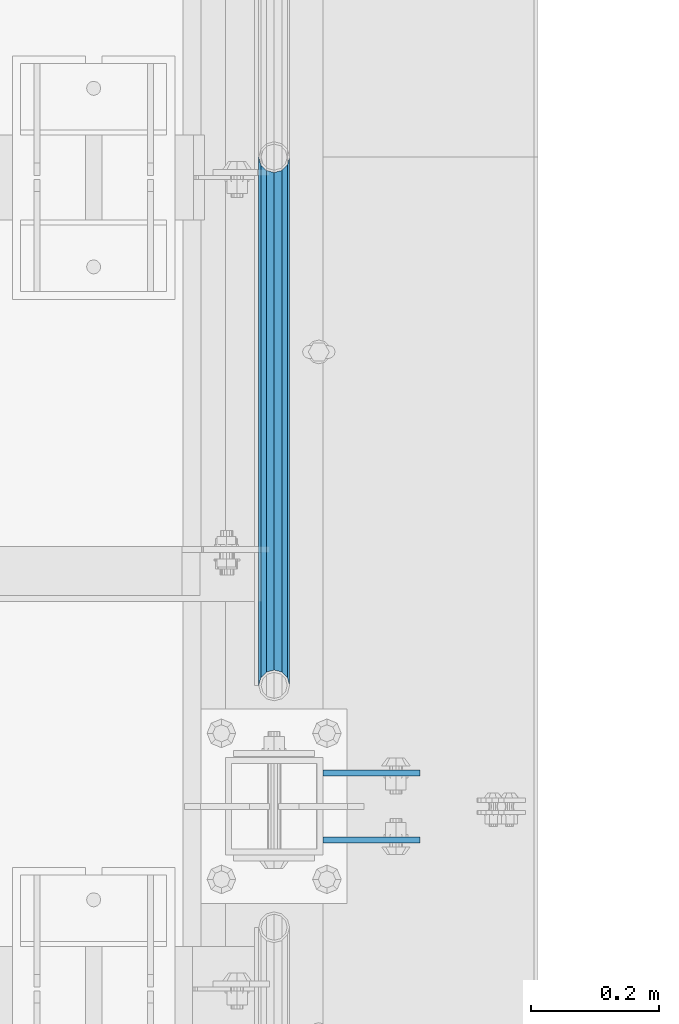
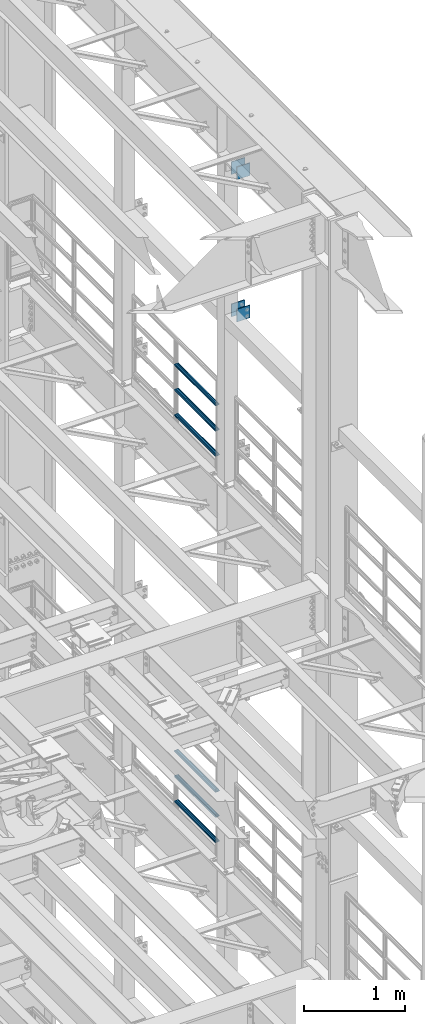
# One storey, part 1345 of 1876: 10 beams, 3 elements without a shape of their own.
"""IFC2X3 building model written with IfcOpenShell, lengths in millimetres."""

from ifc_helpers import new_model, si_unit, frame, origin_with_axes, place, context, subcontext, project, spatial, faceted_brep, material, type_object, element, aggregate, save


model = new_model("IFC2X3")

# Units and contexts
model_context = context("Model", 3, precision=1e-05, world=origin_with_axes())
body_context = subcontext(model_context, "Body", "Model", "MODEL_VIEW")
ifc_project = project(units=[si_unit("LENGTHUNIT", "METRE", prefix="MILLI"), si_unit("AREAUNIT", "SQUARE_METRE"), si_unit("VOLUMEUNIT", "CUBIC_METRE"), si_unit("MASSUNIT", "GRAM", prefix="KILO"), si_unit("TIMEUNIT", "SECOND"), si_unit("PLANEANGLEUNIT", "RADIAN"), si_unit("SOLIDANGLEUNIT", "STERADIAN"), si_unit("THERMODYNAMICTEMPERATUREUNIT", "DEGREE_CELSIUS"), si_unit("LUMINOUSINTENSITYUNIT", "LUMEN")], contexts=[model_context])

# Site, building, storey
site_placement = place(None, origin_with_axes())
site = spatial("IfcSite", under=ifc_project, at=site_placement, CompositionType="ELEMENT")
building_placement = place(site_placement, origin_with_axes())
building = spatial("IfcBuilding", under=site, at=building_placement, Name="Undefined", CompositionType="ELEMENT")
storey_placement = place(building_placement, origin_with_axes())
storey = spatial("IfcBuildingStorey", under=building, at=storey_placement, Name="Undefined", CompositionType="ELEMENT", Elevation=0.0)

# Assembly, beams
assembly_1_placement = place(storey_placement, origin_with_axes())
assembly_1 = element("IfcElementAssembly", 1, at=assembly_1_placement, inside=storey, Name="BEAM", AssemblyPlace="NOTDEFINED", PredefinedType="RIGID_FRAME")
ifc_material_1 = material(Name="STEEL/A36")
beam_type_1 = type_object("IfcBeamType", PredefinedType="NOTDEFINED")
beam_1_placement = place(assembly_1_placement, frame((7696.20000025489, 9704.3875, 21678.9), z_axis=(0.0, 0.0, -1.0), x_axis=(1.0, 0.0, 0.0)))
beam_1 = element("IfcBeam", 2, at=beam_1_placement, type_object=beam_type_1, material=ifc_material_1, Name="PLATE", context=body_context, shape_type="Brep", body=[
    faceted_brep([(0.0, 4.76249999999982, -76.1999999999998), (3.63797880709171e-12, 4.76249999999982, 76.1999969482422), (152.399993896484, 4.76250000000073, 76.1999969482422), (152.4, 4.76249999999982, -76.1999999999998), (3.63797880709171e-12, -4.76249999999982, 76.1999969482422), (152.399993896484, -4.76250000000073, 76.1999969482422), (0.0, -4.76249999999982, -76.1999999999998), (152.4, -4.76249999999982, -76.1999999999998)], [[[0, 1, 2, 3]], [[4, 5, 2, 1]], [[4, 6, 7, 5]], [[6, 0, 3, 7]], [[5, 7, 3, 2]], [[6, 4, 1, 0]]]),
])
beam_2_placement = place(assembly_1_placement, frame((7696.20000025489, 9599.6125, 21678.9), z_axis=(0.0, 0.0, -1.0), x_axis=(1.0, 0.0, 0.0)))
beam_2 = element("IfcBeam", 3, at=beam_2_placement, type_object=beam_type_1, material=ifc_material_1, Name="PLATE", context=body_context, shape_type="Brep", body=[
    faceted_brep([(0.0, 4.76249999999982, -76.1999999999998), (3.63797880709171e-12, 4.76249999999982, 76.1999969482422), (152.399993896484, 4.76250000000073, 76.1999969482422), (152.4, 4.76249999999982, -76.1999999999998), (3.63797880709171e-12, -4.76249999999982, 76.1999969482422), (152.399993896484, -4.76250000000073, 76.1999969482422), (0.0, -4.76249999999982, -76.1999999999998), (152.4, -4.76249999999982, -76.1999999999998)], [[[0, 1, 2, 3]], [[4, 5, 2, 1]], [[4, 6, 7, 5]], [[6, 0, 3, 7]], [[5, 7, 3, 2]], [[6, 4, 1, 0]]]),
])
beam_3_placement = place(assembly_1_placement, frame((7696.20000025489, 9704.3875, 19958.05), z_axis=(0.0, 0.0, -1.0), x_axis=(1.0, 0.0, 0.0)))
beam_3 = element("IfcBeam", 4, at=beam_3_placement, type_object=beam_type_1, material=ifc_material_1, Name="PLATE", context=body_context, shape_type="Brep", body=[
    faceted_brep([(0.0, 4.76249999999982, -76.1999999999998), (3.63797880709171e-12, 4.76249999999982, 76.1999969482422), (152.399993896484, 4.76250000000073, 76.1999969482422), (152.4, 4.76249999999982, -76.1999999999998), (3.63797880709171e-12, -4.76249999999982, 76.1999969482422), (152.399993896484, -4.76250000000073, 76.1999969482422), (0.0, -4.76249999999982, -76.1999999999998), (152.4, -4.76249999999982, -76.1999999999998)], [[[0, 1, 2, 3]], [[4, 5, 2, 1]], [[4, 6, 7, 5]], [[6, 0, 3, 7]], [[5, 7, 3, 2]], [[6, 4, 1, 0]]]),
])
beam_4_placement = place(assembly_1_placement, frame((7696.20000025489, 9599.6125, 19958.05), z_axis=(0.0, 0.0, -1.0), x_axis=(1.0, 0.0, 0.0)))
beam_4 = element("IfcBeam", 5, at=beam_4_placement, type_object=beam_type_1, material=ifc_material_1, Name="PLATE", context=body_context, shape_type="Brep", body=[
    faceted_brep([(0.0, 4.76249999999982, -76.1999999999998), (3.63797880709171e-12, 4.76249999999982, 76.1999969482422), (152.399993896484, 4.76250000000073, 76.1999969482422), (152.4, 4.76249999999982, -76.1999999999998), (3.63797880709171e-12, -4.76249999999982, 76.1999969482422), (152.399993896484, -4.76250000000073, 76.1999969482422), (0.0, -4.76249999999982, -76.1999999999998), (152.4, -4.76249999999982, -76.1999999999998)], [[[0, 1, 2, 3]], [[4, 5, 2, 1]], [[4, 6, 7, 5]], [[6, 0, 3, 7]], [[5, 7, 3, 2]], [[6, 4, 1, 0]]]),
])
aggregate(assembly_1, [beam_1, beam_2, beam_3, beam_4])

assembly_2_placement = place(storey_placement, origin_with_axes())
assembly_2 = element("IfcElementAssembly", 6, at=assembly_2_placement, inside=storey, Name="RAIL", AssemblyPlace="NOTDEFINED", PredefinedType="RIGID_FRAME")
ifc_material_2 = material()
beam_type_2 = type_object("IfcBeamType", Name="PIPE1-1/2SCH40", PredefinedType="NOTDEFINED")
beam_5_placement = place(assembly_2_placement, frame((7620.0, 10668.0, 18145.125), z_axis=(0.0, 0.0, 1.0), x_axis=(0.0, -1.0, 0.0)))
beam_5 = element("IfcBeam", 7, at=beam_5_placement, type_object=beam_type_2, material=ifc_material_2, Name="RAIL", ObjectType="PIPE1-1/2SCH40", context=body_context, shape_type="Brep", body=[
    faceted_brep([(805.872807006681, -12.0649999999996, 20.8971929933177), (805.872807006683, -12.0649999999996, 15.8661214311796), (805.379378568819, -10.2235000000001, 17.7076214311819), (802.640000000001, 0.0, 20.4470000000001), (802.640000000001, 0.0, 24.130000000001), (805.379378568819, 10.2235000000001, 17.7076214311819), (805.872807006683, 12.0649999999996, 15.8661214311796), (805.872807006681, 12.0649999999996, 20.8971929933177), (826.77, 24.1300000000001, 0.0), (814.705, 20.8971929933186, 12.0649999999987), (814.705, 20.8971929933186, -12.0649999999987), (811.515428437862, 17.7076214311801, 10.2235000000001), (814.254807006682, 20.4470000000001, 0.0), (811.515428437862, 17.7076214311801, -10.2235000000001), (805.872807006683, 12.0649999999996, -15.8661214311796), (805.872807006681, 12.0649999999996, -20.8971929933177), (805.379378568819, 10.2235000000001, -17.7076214311819), (802.640000000001, 0.0, -20.4470000000001), (802.640000000001, 0.0, -24.130000000001), (805.872807006683, -12.0649999999996, -15.8661214311796), (805.872807006681, -12.0649999999996, -20.8971929933177), (805.379378568819, -10.2235000000001, -17.7076214311819), (826.77, -24.1300000000001, 0.0), (814.705, -20.8971929933186, -12.0649999999987), (814.705, -20.8971929933186, 12.0649999999987), (811.515428437862, -17.7076214311801, -10.2235000000001), (814.254807006682, -20.4470000000001, 0.0), (811.515428437862, -17.7076214311801, 10.2235000000001), (12.0650000000064, -20.8971929933177, -12.0649999999987), (20.8971929933249, -12.0650000000005, -20.8971929933177), (0.0, 24.1299999999992, 0.0), (12.0650000000064, 20.8971929933177, -12.0649999999987), (12.0650000000064, 20.8971929933177, 12.0649999999987), (20.8971929933249, 12.0650000000005, 20.8971929933177), (24.1300000000064, 0.0, 24.130000000001), (20.8971929933249, 12.0650000000005, -20.8971929933177), (24.1300000000063, 0.0, -24.130000000001), (24.1300000000063, 0.0, -20.4470000000001), (20.8971929933249, -12.0650000000005, -15.8661214311796), (21.3906214311868, -10.2235000000001, -17.7076214311819), (21.3906214311868, 10.2235000000001, -17.7076214311819), (20.8971929933249, 12.0650000000005, -15.8661214311796), (15.2545715621445, 17.7076214311801, -10.2235000000001), (12.5151929933249, 20.4470000000001, 0.0), (15.2545715621445, 17.7076214311801, 10.2235000000001), (20.8971929933249, 12.0650000000005, 15.8661214311796), (21.3906214311868, 10.2235000000001, 17.7076214311819), (24.1300000000064, 0.0, 20.4470000000001), (21.3906214311868, -10.2235000000001, 17.7076214311819), (20.8971929933249, -12.0650000000005, 15.8661214311796), (20.8971929933249, -12.0650000000005, 20.8971929933177), (12.0650000000064, -20.8971929933177, 12.0649999999987), (0.0, -24.1299999999992, 0.0), (15.2545715621445, -17.7076214311801, 10.2235000000001), (12.5151929933249, -20.4470000000001, 0.0), (15.2545715621445, -17.7076214311801, -10.2235000000001)], [[[0, 1, 2, 3, 4]], [[4, 3, 5, 6, 7]], [[8, 9, 10]], [[7, 6, 11, 12, 13, 14, 15, 10, 9]], [[16, 17, 18, 15, 14]], [[19, 20, 18, 17, 21]], [[22, 23, 24]], [[24, 23, 20, 19, 25, 26, 27, 1, 0]], [[28, 29, 20, 23]], [[30, 31, 32]], [[33, 34, 4, 7]], [[32, 33, 7, 9]], [[30, 32, 9, 8]], [[31, 30, 8, 10]], [[35, 31, 10, 15]], [[36, 35, 15, 18]], [[29, 36, 18, 20]], [[37, 36, 29, 38, 39]], [[40, 41, 35, 36, 37]], [[32, 31, 35, 41, 42, 43, 44, 45, 33]], [[33, 45, 46, 47, 34]], [[34, 47, 48, 49, 50]], [[34, 50, 0, 4]], [[50, 51, 24, 0]], [[51, 52, 22, 24]], [[52, 28, 23, 22]], [[51, 28, 52]], [[50, 49, 53, 54, 55, 38, 29, 28, 51]], [[55, 54, 26, 25]], [[21, 39, 38, 55, 25, 19]], [[37, 39, 21, 17]], [[40, 37, 17, 16]], [[42, 41, 40, 16, 14, 13]], [[43, 42, 13, 12]], [[44, 43, 12, 11]], [[5, 46, 45, 44, 11, 6]], [[47, 46, 5, 3]], [[48, 47, 3, 2]], [[53, 49, 48, 2, 1, 27]], [[54, 53, 27, 26]]]),
])
beam_6_placement = place(assembly_2_placement, frame((7620.0, 9841.23, 18449.925), z_axis=(0.0, 0.0, -1.0), x_axis=(0.0, 1.0, 0.0)))
beam_6 = element("IfcBeam", 8, at=beam_6_placement, type_object=beam_type_2, material=ifc_material_2, Name="RAIL", ObjectType="PIPE1-1/2SCH40", context=body_context, shape_type="Brep", body=[
    faceted_brep([(0.0, 24.1299999999992, 0.0), (12.0650000000064, 20.8971929933177, -12.0649999999987), (12.0650000000064, 20.8971929933177, 12.0649999999987), (12.0650000000064, -20.8971929933177, 12.0649999999987), (12.0650000000064, -20.8971929933177, -12.0649999999987), (0.0, -24.1299999999992, 0.0), (20.8971929933249, -12.0650000000005, 20.8971929933177), (20.8971929933249, -12.0650000000005, 15.8661214311796), (15.2545715621445, -17.7076214311801, 10.2235000000001), (12.5151929933249, -20.4470000000001, 0.0), (15.2545715621445, -17.7076214311801, -10.2235000000001), (20.8971929933249, -12.0650000000005, -15.8661214311796), (20.8971929933249, -12.0650000000005, -20.8971929933177), (24.1300000000063, 0.0, -20.4470000000001), (24.1300000000063, 0.0, -24.130000000001), (21.3906214311868, -10.2235000000001, -17.7076214311819), (21.3906214311868, 10.2235000000001, -17.7076214311819), (20.8971929933249, 12.0650000000005, -15.8661214311796), (20.8971929933249, 12.0650000000005, -20.8971929933177), (15.2545715621445, 17.7076214311801, -10.2235000000001), (12.5151929933249, 20.4470000000001, 0.0), (15.2545715621445, 17.7076214311801, 10.2235000000001), (20.8971929933249, 12.0650000000005, 15.8661214311796), (20.8971929933249, 12.0650000000005, 20.8971929933177), (21.3906214311868, 10.2235000000001, 17.7076214311819), (24.1300000000064, 0.0, 20.4470000000001), (24.1300000000064, 0.0, 24.130000000001), (21.3906214311868, -10.2235000000001, 17.7076214311819), (826.77, 24.1300000000001, 0.0), (814.705, 20.8971929933186, -12.0649999999987), (805.872807006681, 12.0649999999996, -20.8971929933177), (826.77, -24.1300000000001, 0.0), (814.705, -20.8971929933186, -12.0649999999987), (814.705, -20.8971929933186, 12.0649999999987), (805.872807006681, -12.0649999999996, 20.8971929933177), (805.872807006681, -12.0649999999996, -20.8971929933177), (802.640000000001, 0.0, -24.130000000001), (805.379378568819, 10.2235000000001, -17.7076214311819), (802.640000000001, 0.0, -20.4470000000001), (805.872807006683, 12.0649999999996, -15.8661214311796), (805.872807006683, -12.0649999999996, -15.8661214311796), (805.379378568819, -10.2235000000001, -17.7076214311819), (811.515428437862, -17.7076214311801, -10.2235000000001), (814.254807006682, -20.4470000000001, 0.0), (811.515428437862, -17.7076214311801, 10.2235000000001), (805.872807006683, -12.0649999999996, 15.8661214311796), (805.379378568819, -10.2235000000001, 17.7076214311819), (802.640000000001, 0.0, 20.4470000000001), (802.640000000001, 0.0, 24.130000000001), (805.872807006681, 12.0649999999996, 20.8971929933177), (814.705, 20.8971929933186, 12.0649999999987), (805.872807006683, 12.0649999999996, 15.8661214311796), (811.515428437862, 17.7076214311801, 10.2235000000001), (814.254807006682, 20.4470000000001, 0.0), (811.515428437862, 17.7076214311801, -10.2235000000001), (805.379378568819, 10.2235000000001, 17.7076214311819)], [[[0, 1, 2]], [[3, 4, 5]], [[6, 7, 8, 9, 10, 11, 12, 4, 3]], [[13, 14, 12, 11, 15]], [[16, 17, 18, 14, 13]], [[2, 1, 18, 17, 19, 20, 21, 22, 23]], [[23, 22, 24, 25, 26]], [[26, 25, 27, 7, 6]], [[1, 0, 28, 29]], [[18, 1, 29, 30]], [[31, 32, 33]], [[6, 3, 33, 34]], [[3, 5, 31, 33]], [[5, 4, 32, 31]], [[4, 12, 35, 32]], [[12, 14, 36, 35]], [[14, 18, 30, 36]], [[37, 38, 36, 30, 39]], [[40, 35, 36, 38, 41]], [[33, 32, 35, 40, 42, 43, 44, 45, 34]], [[34, 45, 46, 47, 48]], [[26, 6, 34, 48]], [[2, 23, 49, 50]], [[23, 26, 48, 49]], [[0, 2, 50, 28]], [[28, 50, 29]], [[49, 51, 52, 53, 54, 39, 30, 29, 50]], [[48, 47, 55, 51, 49]], [[25, 24, 55, 47]], [[55, 24, 22, 21, 52, 51]], [[21, 20, 53, 52]], [[20, 19, 54, 53]], [[19, 17, 16, 37, 39, 54]], [[16, 13, 38, 37]], [[13, 15, 41, 38]], [[41, 15, 11, 10, 42, 40]], [[10, 9, 43, 42]], [[9, 8, 44, 43]], [[8, 7, 27, 46, 45, 44]], [[27, 25, 47, 46]]]),
])
beam_7_placement = place(assembly_2_placement, frame((7620.0, 9841.23, 18754.725), z_axis=(0.0, 0.0, -1.0), x_axis=(0.0, 1.0, 0.0)))
beam_7 = element("IfcBeam", 9, at=beam_7_placement, type_object=beam_type_2, material=ifc_material_2, Name="RAIL", ObjectType="PIPE1-1/2SCH40", context=body_context, shape_type="Brep", body=[
    faceted_brep([(0.0, 24.1299999999992, 0.0), (12.0650000000064, 20.8971929933177, -12.0649999999987), (12.0650000000064, 20.8971929933177, 12.0649999999987), (12.0650000000064, -20.8971929933177, 12.0649999999987), (12.0650000000064, -20.8971929933177, -12.0649999999987), (0.0, -24.1299999999992, 0.0), (20.8971929933249, -12.0650000000005, 20.8971929933177), (20.8971929933249, -12.0650000000005, 15.8661214311796), (15.2545715621445, -17.7076214311801, 10.2235000000001), (12.5151929933249, -20.4470000000001, 0.0), (15.2545715621445, -17.7076214311801, -10.2235000000001), (20.8971929933249, -12.0650000000005, -15.8661214311796), (20.8971929933249, -12.0650000000005, -20.8971929933177), (24.1300000000063, 0.0, -20.4470000000001), (24.1300000000063, 0.0, -24.130000000001), (21.3906214311868, -10.2235000000001, -17.7076214311819), (21.3906214311868, 10.2235000000001, -17.7076214311819), (20.8971929933249, 12.0650000000005, -15.8661214311796), (20.8971929933249, 12.0650000000005, -20.8971929933177), (15.2545715621445, 17.7076214311801, -10.2235000000001), (12.5151929933249, 20.4470000000001, 0.0), (15.2545715621445, 17.7076214311801, 10.2235000000001), (20.8971929933249, 12.0650000000005, 15.8661214311796), (20.8971929933249, 12.0650000000005, 20.8971929933177), (21.3906214311868, 10.2235000000001, 17.7076214311819), (24.1300000000064, 0.0, 20.4470000000001), (24.1300000000064, 0.0, 24.130000000001), (21.3906214311868, -10.2235000000001, 17.7076214311819), (826.77, 24.1300000000001, 0.0), (814.705, 20.8971929933186, -12.0649999999987), (805.872807006681, 12.0649999999996, -20.8971929933177), (826.77, -24.1300000000001, 0.0), (814.705, -20.8971929933186, -12.0649999999987), (814.705, -20.8971929933186, 12.0649999999987), (805.872807006681, -12.0649999999996, 20.8971929933177), (805.872807006681, -12.0649999999996, -20.8971929933177), (802.640000000001, 0.0, -24.130000000001), (805.379378568819, 10.2235000000001, -17.7076214311819), (802.640000000001, 0.0, -20.4470000000001), (805.872807006683, 12.0649999999996, -15.8661214311796), (805.872807006683, -12.0649999999996, -15.8661214311796), (805.379378568819, -10.2235000000001, -17.7076214311819), (811.515428437862, -17.7076214311801, -10.2235000000001), (814.254807006682, -20.4470000000001, 0.0), (811.515428437862, -17.7076214311801, 10.2235000000001), (805.872807006683, -12.0649999999996, 15.8661214311796), (805.379378568819, -10.2235000000001, 17.7076214311819), (802.640000000001, 0.0, 20.4470000000001), (802.640000000001, 0.0, 24.130000000001), (805.872807006681, 12.0649999999996, 20.8971929933177), (814.705, 20.8971929933186, 12.0649999999987), (805.872807006683, 12.0649999999996, 15.8661214311796), (811.515428437862, 17.7076214311801, 10.2235000000001), (814.254807006682, 20.4470000000001, 0.0), (811.515428437862, 17.7076214311801, -10.2235000000001), (805.379378568819, 10.2235000000001, 17.7076214311819)], [[[0, 1, 2]], [[3, 4, 5]], [[6, 7, 8, 9, 10, 11, 12, 4, 3]], [[13, 14, 12, 11, 15]], [[16, 17, 18, 14, 13]], [[2, 1, 18, 17, 19, 20, 21, 22, 23]], [[23, 22, 24, 25, 26]], [[26, 25, 27, 7, 6]], [[1, 0, 28, 29]], [[18, 1, 29, 30]], [[31, 32, 33]], [[6, 3, 33, 34]], [[3, 5, 31, 33]], [[5, 4, 32, 31]], [[4, 12, 35, 32]], [[12, 14, 36, 35]], [[14, 18, 30, 36]], [[37, 38, 36, 30, 39]], [[40, 35, 36, 38, 41]], [[33, 32, 35, 40, 42, 43, 44, 45, 34]], [[34, 45, 46, 47, 48]], [[26, 6, 34, 48]], [[2, 23, 49, 50]], [[23, 26, 48, 49]], [[0, 2, 50, 28]], [[28, 50, 29]], [[49, 51, 52, 53, 54, 39, 30, 29, 50]], [[48, 47, 55, 51, 49]], [[25, 24, 55, 47]], [[55, 24, 22, 21, 52, 51]], [[21, 20, 53, 52]], [[20, 19, 54, 53]], [[19, 17, 16, 37, 39, 54]], [[16, 13, 38, 37]], [[13, 15, 41, 38]], [[41, 15, 11, 10, 42, 40]], [[10, 9, 43, 42]], [[9, 8, 44, 43]], [[8, 7, 27, 46, 45, 44]], [[27, 25, 47, 46]]]),
])
aggregate(assembly_2, [beam_5, beam_6, beam_7])

assembly_3_placement = place(storey_placement, origin_with_axes())
assembly_3 = element("IfcElementAssembly", 10, at=assembly_3_placement, inside=storey, Name="RAIL", AssemblyPlace="NOTDEFINED", PredefinedType="RIGID_FRAME")
beam_8_placement = place(assembly_3_placement, frame((7620.0, 10668.0, 13471.525), z_axis=(0.0, 0.0, 1.0), x_axis=(0.0, -1.0, 0.0)))
beam_8 = element("IfcBeam", 11, at=beam_8_placement, type_object=beam_type_2, material=ifc_material_2, Name="RAIL", ObjectType="PIPE1-1/2SCH40", context=body_context, shape_type="Brep", body=[
    faceted_brep([(805.872807006681, -12.0649999999996, 20.8971929933177), (805.872807006683, -12.0649999999996, 15.8661214311796), (805.379378568819, -10.2235000000001, 17.7076214311819), (802.640000000001, 0.0, 20.4470000000001), (802.640000000001, 0.0, 24.130000000001), (805.379378568819, 10.2235000000001, 17.7076214311819), (805.872807006683, 12.0649999999996, 15.8661214311796), (805.872807006681, 12.0649999999996, 20.8971929933177), (826.77, 24.1300000000001, 0.0), (814.705, 20.8971929933186, 12.0649999999987), (814.705, 20.8971929933186, -12.0649999999987), (811.515428437862, 17.7076214311801, 10.2235000000001), (814.254807006682, 20.4470000000001, 0.0), (811.515428437862, 17.7076214311801, -10.2235000000001), (805.872807006683, 12.0649999999996, -15.8661214311796), (805.872807006681, 12.0649999999996, -20.8971929933177), (805.379378568819, 10.2235000000001, -17.7076214311819), (802.640000000001, 0.0, -20.4470000000001), (802.640000000001, 0.0, -24.130000000001), (805.872807006683, -12.0649999999996, -15.8661214311796), (805.872807006681, -12.0649999999996, -20.8971929933177), (805.379378568819, -10.2235000000001, -17.7076214311819), (826.77, -24.1300000000001, 0.0), (814.705, -20.8971929933186, -12.0649999999987), (814.705, -20.8971929933186, 12.0649999999987), (811.515428437862, -17.7076214311801, -10.2235000000001), (814.254807006682, -20.4470000000001, 0.0), (811.515428437862, -17.7076214311801, 10.2235000000001), (12.0650000000064, -20.8971929933177, -12.0649999999987), (20.8971929933249, -12.0650000000005, -20.8971929933177), (0.0, 24.1299999999992, 0.0), (12.0650000000064, 20.8971929933177, -12.0649999999987), (12.0650000000064, 20.8971929933177, 12.0649999999987), (20.8971929933249, 12.0650000000005, 20.8971929933177), (24.1300000000064, 0.0, 24.130000000001), (20.8971929933249, 12.0650000000005, -20.8971929933177), (24.1300000000063, 0.0, -24.130000000001), (24.1300000000063, 0.0, -20.4470000000001), (20.8971929933249, -12.0650000000005, -15.8661214311796), (21.3906214311868, -10.2235000000001, -17.7076214311819), (21.3906214311868, 10.2235000000001, -17.7076214311819), (20.8971929933249, 12.0650000000005, -15.8661214311796), (15.2545715621445, 17.7076214311801, -10.2235000000001), (12.5151929933249, 20.4470000000001, 0.0), (15.2545715621445, 17.7076214311801, 10.2235000000001), (20.8971929933249, 12.0650000000005, 15.8661214311796), (21.3906214311868, 10.2235000000001, 17.7076214311819), (24.1300000000064, 0.0, 20.4470000000001), (21.3906214311868, -10.2235000000001, 17.7076214311819), (20.8971929933249, -12.0650000000005, 15.8661214311796), (20.8971929933249, -12.0650000000005, 20.8971929933177), (12.0650000000064, -20.8971929933177, 12.0649999999987), (0.0, -24.1299999999992, 0.0), (15.2545715621445, -17.7076214311801, 10.2235000000001), (12.5151929933249, -20.4470000000001, 0.0), (15.2545715621445, -17.7076214311801, -10.2235000000001)], [[[0, 1, 2, 3, 4]], [[4, 3, 5, 6, 7]], [[8, 9, 10]], [[7, 6, 11, 12, 13, 14, 15, 10, 9]], [[16, 17, 18, 15, 14]], [[19, 20, 18, 17, 21]], [[22, 23, 24]], [[24, 23, 20, 19, 25, 26, 27, 1, 0]], [[28, 29, 20, 23]], [[30, 31, 32]], [[33, 34, 4, 7]], [[32, 33, 7, 9]], [[30, 32, 9, 8]], [[31, 30, 8, 10]], [[35, 31, 10, 15]], [[36, 35, 15, 18]], [[29, 36, 18, 20]], [[37, 36, 29, 38, 39]], [[40, 41, 35, 36, 37]], [[32, 31, 35, 41, 42, 43, 44, 45, 33]], [[33, 45, 46, 47, 34]], [[34, 47, 48, 49, 50]], [[34, 50, 0, 4]], [[50, 51, 24, 0]], [[51, 52, 22, 24]], [[52, 28, 23, 22]], [[51, 28, 52]], [[50, 49, 53, 54, 55, 38, 29, 28, 51]], [[55, 54, 26, 25]], [[21, 39, 38, 55, 25, 19]], [[37, 39, 21, 17]], [[40, 37, 17, 16]], [[42, 41, 40, 16, 14, 13]], [[43, 42, 13, 12]], [[44, 43, 12, 11]], [[5, 46, 45, 44, 11, 6]], [[47, 46, 5, 3]], [[48, 47, 3, 2]], [[53, 49, 48, 2, 1, 27]], [[54, 53, 27, 26]]]),
])
beam_9_placement = place(assembly_3_placement, frame((7620.0, 9841.23, 13776.325), z_axis=(0.0, 0.0, -1.0), x_axis=(0.0, 1.0, 0.0)))
beam_9 = element("IfcBeam", 12, at=beam_9_placement, type_object=beam_type_2, material=ifc_material_2, Name="RAIL", ObjectType="PIPE1-1/2SCH40", context=body_context, shape_type="Brep", body=[
    faceted_brep([(0.0, 24.1299999999992, 0.0), (12.0650000000064, 20.8971929933177, -12.0649999999987), (12.0650000000064, 20.8971929933177, 12.0649999999987), (12.0650000000064, -20.8971929933177, 12.0649999999987), (12.0650000000064, -20.8971929933177, -12.0649999999987), (0.0, -24.1299999999992, 0.0), (20.8971929933249, -12.0650000000005, 20.8971929933177), (20.8971929933249, -12.0650000000005, 15.8661214311796), (15.2545715621445, -17.7076214311801, 10.2235000000001), (12.5151929933249, -20.4470000000001, 0.0), (15.2545715621445, -17.7076214311801, -10.2235000000001), (20.8971929933249, -12.0650000000005, -15.8661214311796), (20.8971929933249, -12.0650000000005, -20.8971929933177), (24.1300000000063, 0.0, -20.4470000000001), (24.1300000000063, 0.0, -24.130000000001), (21.3906214311868, -10.2235000000001, -17.7076214311819), (21.3906214311868, 10.2235000000001, -17.7076214311819), (20.8971929933249, 12.0650000000005, -15.8661214311796), (20.8971929933249, 12.0650000000005, -20.8971929933177), (15.2545715621445, 17.7076214311801, -10.2235000000001), (12.5151929933249, 20.4470000000001, 0.0), (15.2545715621445, 17.7076214311801, 10.2235000000001), (20.8971929933249, 12.0650000000005, 15.8661214311796), (20.8971929933249, 12.0650000000005, 20.8971929933177), (21.3906214311868, 10.2235000000001, 17.7076214311819), (24.1300000000064, 0.0, 20.4470000000001), (24.1300000000064, 0.0, 24.130000000001), (21.3906214311868, -10.2235000000001, 17.7076214311819), (826.77, 24.1300000000001, 0.0), (814.705, 20.8971929933186, -12.0649999999987), (805.872807006681, 12.0649999999996, -20.8971929933177), (826.77, -24.1300000000001, 0.0), (814.705, -20.8971929933186, -12.0649999999987), (814.705, -20.8971929933186, 12.0649999999987), (805.872807006681, -12.0649999999996, 20.8971929933177), (805.872807006681, -12.0649999999996, -20.8971929933177), (802.640000000001, 0.0, -24.130000000001), (805.379378568819, 10.2235000000001, -17.7076214311819), (802.640000000001, 0.0, -20.4470000000001), (805.872807006683, 12.0649999999996, -15.8661214311796), (805.872807006683, -12.0649999999996, -15.8661214311796), (805.379378568819, -10.2235000000001, -17.7076214311819), (811.515428437862, -17.7076214311801, -10.2235000000001), (814.254807006682, -20.4470000000001, 0.0), (811.515428437862, -17.7076214311801, 10.2235000000001), (805.872807006683, -12.0649999999996, 15.8661214311796), (805.379378568819, -10.2235000000001, 17.7076214311819), (802.640000000001, 0.0, 20.4470000000001), (802.640000000001, 0.0, 24.130000000001), (805.872807006681, 12.0649999999996, 20.8971929933177), (814.705, 20.8971929933186, 12.0649999999987), (805.872807006683, 12.0649999999996, 15.8661214311796), (811.515428437862, 17.7076214311801, 10.2235000000001), (814.254807006682, 20.4470000000001, 0.0), (811.515428437862, 17.7076214311801, -10.2235000000001), (805.379378568819, 10.2235000000001, 17.7076214311819)], [[[0, 1, 2]], [[3, 4, 5]], [[6, 7, 8, 9, 10, 11, 12, 4, 3]], [[13, 14, 12, 11, 15]], [[16, 17, 18, 14, 13]], [[2, 1, 18, 17, 19, 20, 21, 22, 23]], [[23, 22, 24, 25, 26]], [[26, 25, 27, 7, 6]], [[1, 0, 28, 29]], [[18, 1, 29, 30]], [[31, 32, 33]], [[6, 3, 33, 34]], [[3, 5, 31, 33]], [[5, 4, 32, 31]], [[4, 12, 35, 32]], [[12, 14, 36, 35]], [[14, 18, 30, 36]], [[37, 38, 36, 30, 39]], [[40, 35, 36, 38, 41]], [[33, 32, 35, 40, 42, 43, 44, 45, 34]], [[34, 45, 46, 47, 48]], [[26, 6, 34, 48]], [[2, 23, 49, 50]], [[23, 26, 48, 49]], [[0, 2, 50, 28]], [[28, 50, 29]], [[49, 51, 52, 53, 54, 39, 30, 29, 50]], [[48, 47, 55, 51, 49]], [[25, 24, 55, 47]], [[55, 24, 22, 21, 52, 51]], [[21, 20, 53, 52]], [[20, 19, 54, 53]], [[19, 17, 16, 37, 39, 54]], [[16, 13, 38, 37]], [[13, 15, 41, 38]], [[41, 15, 11, 10, 42, 40]], [[10, 9, 43, 42]], [[9, 8, 44, 43]], [[8, 7, 27, 46, 45, 44]], [[27, 25, 47, 46]]]),
])
beam_10_placement = place(assembly_3_placement, frame((7620.0, 9841.23, 14081.125), z_axis=(0.0, 0.0, -1.0), x_axis=(0.0, 1.0, 0.0)))
beam_10 = element("IfcBeam", 13, at=beam_10_placement, type_object=beam_type_2, material=ifc_material_2, Name="RAIL", ObjectType="PIPE1-1/2SCH40", context=body_context, shape_type="Brep", body=[
    faceted_brep([(0.0, 24.1299999999992, 0.0), (12.0650000000064, 20.8971929933177, -12.0649999999987), (12.0650000000064, 20.8971929933177, 12.0649999999987), (12.0650000000064, -20.8971929933177, 12.0649999999987), (12.0650000000064, -20.8971929933177, -12.0649999999987), (0.0, -24.1299999999992, 0.0), (20.8971929933249, -12.0650000000005, 20.8971929933177), (20.8971929933249, -12.0650000000005, 15.8661214311796), (15.2545715621445, -17.7076214311801, 10.2235000000001), (12.5151929933249, -20.4470000000001, 0.0), (15.2545715621445, -17.7076214311801, -10.2235000000001), (20.8971929933249, -12.0650000000005, -15.8661214311796), (20.8971929933249, -12.0650000000005, -20.8971929933177), (24.1300000000063, 0.0, -20.4470000000001), (24.1300000000063, 0.0, -24.130000000001), (21.3906214311868, -10.2235000000001, -17.7076214311819), (21.3906214311868, 10.2235000000001, -17.7076214311819), (20.8971929933249, 12.0650000000005, -15.8661214311796), (20.8971929933249, 12.0650000000005, -20.8971929933177), (15.2545715621445, 17.7076214311801, -10.2235000000001), (12.5151929933249, 20.4470000000001, 0.0), (15.2545715621445, 17.7076214311801, 10.2235000000001), (20.8971929933249, 12.0650000000005, 15.8661214311796), (20.8971929933249, 12.0650000000005, 20.8971929933177), (21.3906214311868, 10.2235000000001, 17.7076214311819), (24.1300000000064, 0.0, 20.4470000000001), (24.1300000000064, 0.0, 24.130000000001), (21.3906214311868, -10.2235000000001, 17.7076214311819), (826.77, 24.1300000000001, 0.0), (814.705, 20.8971929933186, -12.0649999999987), (805.872807006681, 12.0649999999996, -20.8971929933177), (826.77, -24.1300000000001, 0.0), (814.705, -20.8971929933186, -12.0649999999987), (814.705, -20.8971929933186, 12.0649999999987), (805.872807006681, -12.0649999999996, 20.8971929933177), (805.872807006681, -12.0649999999996, -20.8971929933177), (802.640000000001, 0.0, -24.130000000001), (805.379378568819, 10.2235000000001, -17.7076214311819), (802.640000000001, 0.0, -20.4470000000001), (805.872807006683, 12.0649999999996, -15.8661214311796), (805.872807006683, -12.0649999999996, -15.8661214311796), (805.379378568819, -10.2235000000001, -17.7076214311819), (811.515428437862, -17.7076214311801, -10.2235000000001), (814.254807006682, -20.4470000000001, 0.0), (811.515428437862, -17.7076214311801, 10.2235000000001), (805.872807006683, -12.0649999999996, 15.8661214311796), (805.379378568819, -10.2235000000001, 17.7076214311819), (802.640000000001, 0.0, 20.4470000000001), (802.640000000001, 0.0, 24.130000000001), (805.872807006681, 12.0649999999996, 20.8971929933177), (814.705, 20.8971929933186, 12.0649999999987), (805.872807006683, 12.0649999999996, 15.8661214311796), (811.515428437862, 17.7076214311801, 10.2235000000001), (814.254807006682, 20.4470000000001, 0.0), (811.515428437862, 17.7076214311801, -10.2235000000001), (805.379378568819, 10.2235000000001, 17.7076214311819)], [[[0, 1, 2]], [[3, 4, 5]], [[6, 7, 8, 9, 10, 11, 12, 4, 3]], [[13, 14, 12, 11, 15]], [[16, 17, 18, 14, 13]], [[2, 1, 18, 17, 19, 20, 21, 22, 23]], [[23, 22, 24, 25, 26]], [[26, 25, 27, 7, 6]], [[1, 0, 28, 29]], [[18, 1, 29, 30]], [[31, 32, 33]], [[6, 3, 33, 34]], [[3, 5, 31, 33]], [[5, 4, 32, 31]], [[4, 12, 35, 32]], [[12, 14, 36, 35]], [[14, 18, 30, 36]], [[37, 38, 36, 30, 39]], [[40, 35, 36, 38, 41]], [[33, 32, 35, 40, 42, 43, 44, 45, 34]], [[34, 45, 46, 47, 48]], [[26, 6, 34, 48]], [[2, 23, 49, 50]], [[23, 26, 48, 49]], [[0, 2, 50, 28]], [[28, 50, 29]], [[49, 51, 52, 53, 54, 39, 30, 29, 50]], [[48, 47, 55, 51, 49]], [[25, 24, 55, 47]], [[55, 24, 22, 21, 52, 51]], [[21, 20, 53, 52]], [[20, 19, 54, 53]], [[19, 17, 16, 37, 39, 54]], [[16, 13, 38, 37]], [[13, 15, 41, 38]], [[41, 15, 11, 10, 42, 40]], [[10, 9, 43, 42]], [[9, 8, 44, 43]], [[8, 7, 27, 46, 45, 44]], [[27, 25, 47, 46]]]),
])
aggregate(assembly_3, [beam_8, beam_9, beam_10])

save(model, "model.ifc")
